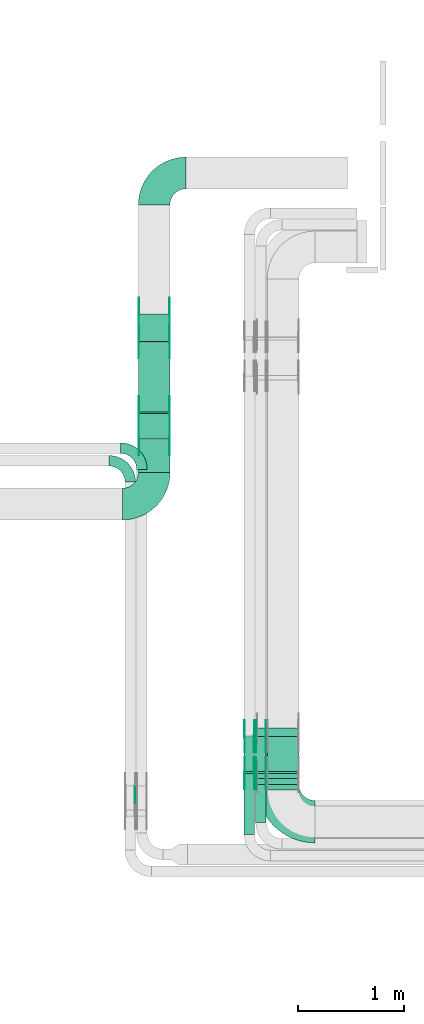
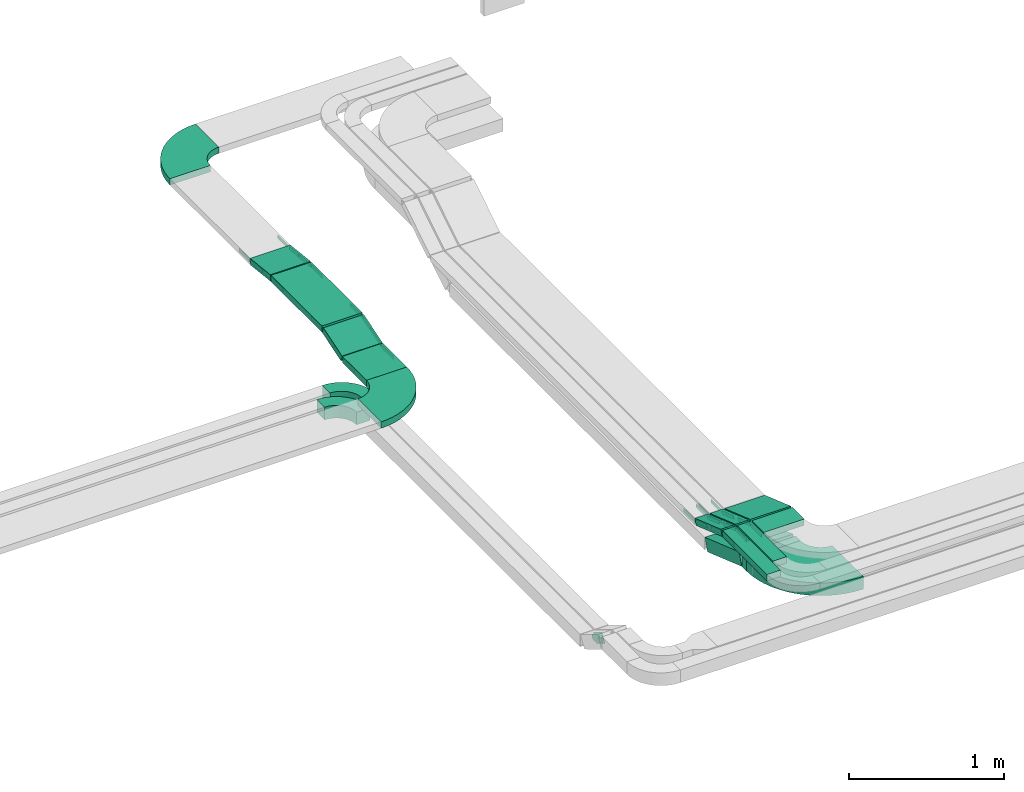
# One storey, part 6 of 27: 38 flow fittings, 12 flow segments.
"""IFC2X3 building model written with IfcOpenShell, lengths in millimetres."""

from ifc_helpers import new_model, entity, si_unit, converted_unit, derived_unit, direction, frame, frame_2d, origin, origin_2d_with_axis, place, context, subcontext, project, spatial, polyline, circle_curve, parameter, trimmed, segment, composite_curve, rectangle, outline, extrude, source, transform, mapped, material, type_object, type_shapes, element, save


model = new_model("IFC2X3")

# Units and contexts
model_context = context("Model", 3, precision=0.01, world=origin(), true_north=direction((6.12303176911189e-17, 1.0)))
body_context = subcontext(model_context, "Body", "Model", "MODEL_VIEW")
ifc_project = project(units=[si_unit("LENGTHUNIT", "METRE", prefix="MILLI"), si_unit("AREAUNIT", "SQUARE_METRE"), si_unit("VOLUMEUNIT", "CUBIC_METRE"), converted_unit("PLANEANGLEUNIT", "DEGREE", entity("IfcRatioMeasure", 0.0174532925199433), si_unit("PLANEANGLEUNIT", "RADIAN"), dimensions=[0, 0, 0, 0, 0, 0, 0]), si_unit("MASSUNIT", "GRAM", prefix="KILO"), derived_unit("MASSDENSITYUNIT", [(si_unit("MASSUNIT", "GRAM", prefix="KILO"), 1), (si_unit("LENGTHUNIT", "METRE"), -3)]), derived_unit("MOMENTOFINERTIAUNIT", [(si_unit("LENGTHUNIT", "METRE"), 4)]), si_unit("TIMEUNIT", "SECOND"), si_unit("FREQUENCYUNIT", "HERTZ"), si_unit("THERMODYNAMICTEMPERATUREUNIT", "DEGREE_CELSIUS"), derived_unit("THERMALTRANSMITTANCEUNIT", [(si_unit("MASSUNIT", "GRAM", prefix="KILO"), 1), (si_unit("THERMODYNAMICTEMPERATUREUNIT", "KELVIN"), -1), (si_unit("TIMEUNIT", "SECOND"), -3)]), derived_unit("VOLUMETRICFLOWRATEUNIT", [(si_unit("LENGTHUNIT", "METRE"), 3), (si_unit("TIMEUNIT", "SECOND"), -1)]), derived_unit("MASSFLOWRATEUNIT", [(si_unit("MASSUNIT", "GRAM", prefix="KILO"), 1), (si_unit("TIMEUNIT", "SECOND"), -1)]), derived_unit("ROTATIONALFREQUENCYUNIT", [(si_unit("TIMEUNIT", "SECOND"), -1)]), si_unit("ELECTRICCURRENTUNIT", "AMPERE"), si_unit("ELECTRICVOLTAGEUNIT", "VOLT"), si_unit("POWERUNIT", "WATT"), si_unit("FORCEUNIT", "NEWTON", prefix="KILO"), si_unit("ILLUMINANCEUNIT", "LUX"), si_unit("LUMINOUSFLUXUNIT", "LUMEN"), si_unit("LUMINOUSINTENSITYUNIT", "CANDELA"), derived_unit("USERDEFINED", [(si_unit("MASSUNIT", "GRAM", prefix="KILO"), -1), (si_unit("LENGTHUNIT", "METRE"), -2), (si_unit("TIMEUNIT", "SECOND"), 3), (si_unit("LUMINOUSFLUXUNIT", "LUMEN"), 1)]), derived_unit("LINEARVELOCITYUNIT", [(si_unit("LENGTHUNIT", "METRE"), 1), (si_unit("TIMEUNIT", "SECOND"), -1)]), si_unit("PRESSUREUNIT", "PASCAL"), derived_unit("USERDEFINED", [(si_unit("LENGTHUNIT", "METRE"), -2), (si_unit("MASSUNIT", "GRAM", prefix="KILO"), 1), (si_unit("TIMEUNIT", "SECOND"), -2)]), derived_unit("LINEARFORCEUNIT", [(si_unit("MASSUNIT", "GRAM", prefix="KILO"), 1), (si_unit("LENGTHUNIT", "METRE"), 1), (si_unit("TIMEUNIT", "SECOND"), -2), (si_unit("LENGTHUNIT", "METRE"), -1)]), derived_unit("PLANARFORCEUNIT", [(si_unit("MASSUNIT", "GRAM", prefix="KILO"), 1), (si_unit("LENGTHUNIT", "METRE"), 1), (si_unit("TIMEUNIT", "SECOND"), -2), (si_unit("LENGTHUNIT", "METRE"), -2)])], contexts=[model_context])

# Site, building, storey
site_placement = place(None, origin())
site = spatial("IfcSite", under=ifc_project, at=site_placement, CompositionType="ELEMENT")
building_placement = place(site_placement, origin())
building = spatial("IfcBuilding", under=site, at=building_placement, CompositionType="ELEMENT")
storey_placement = place(building_placement, origin())
storey = spatial("IfcBuildingStorey", under=building, at=storey_placement, CompositionType="ELEMENT", Elevation=0.0)

# Flow segments
cable_carrier_segment_type = type_object("IfcCableCarrierSegmentType", PredefinedType="CABLETRAYSEGMENT")
flow_segment_1_placement = place(storey_placement, frame((14180.0, 12648.73, 3230.0)))
element("IfcFlowSegment", 1, at=flow_segment_1_placement, inside=storey, type_object=cable_carrier_segment_type, context=body_context, shape_type="SweptSolid", body=[
    extrude(rectangle(XDim=656.864231681176, YDim=300.000000000001, at=origin_2d_with_axis()), frame((150.0, 328.43, 0.0), z_axis=(0.0, 0.0, 1.0), x_axis=(0.0, -1.0, 0.0)), (0.0, 0.0, 1.0), 50.0000000000011),
])
flow_segment_2_placement = place(storey_placement, frame((15400.0, 9071.0, 3350.0)))
element("IfcFlowSegment", 2, at=flow_segment_2_placement, inside=storey, type_object=cable_carrier_segment_type, context=body_context, shape_type="SweptSolid", body=[
    extrude(rectangle(XDim=153.10288471087, YDim=300.000000000001, at=origin_2d_with_axis()), frame((150.0, 76.55, 0.0), z_axis=(0.0, 0.0, 1.0), x_axis=(0.0, 1.0, 0.0)), (0.0, 0.0, 1.0), 49.9999999999995),
])
flow_segment_3_placement = place(storey_placement, frame((15290.0, 8761.0, 3350.0)))
element("IfcFlowSegment", 3, at=flow_segment_3_placement, inside=storey, type_object=cable_carrier_segment_type, context=body_context, shape_type="SweptSolid", body=[
    extrude(rectangle(XDim=463.102884710998, YDim=99.9999999999989, at=origin_2d_with_axis()), frame((50.0, 231.55, 0.0), z_axis=(0.0, 0.0, 1.0), x_axis=(0.0, 1.0, 0.0)), (0.0, 0.0, 1.0), 49.9999999999989),
])
flow_segment_4_placement = place(storey_placement, frame((15180.0, 8651.0, 3350.0)))
element("IfcFlowSegment", 4, at=flow_segment_4_placement, inside=storey, type_object=cable_carrier_segment_type, context=body_context, shape_type="SweptSolid", body=[
    extrude(rectangle(XDim=573.102884710878, YDim=99.9999999999989, at=origin_2d_with_axis()), frame((50.0, 286.55, 0.0), z_axis=(0.0, 0.0, 1.0), x_axis=(0.0, 1.0, 0.0)), (0.0, 0.0, 1.0), 50.0000000000005),
])
flow_segment_5_placement = place(storey_placement, frame((15400.0, 9227.36, 3233.32)))
element("IfcFlowSegment", 5, at=flow_segment_5_placement, inside=storey, type_object=cable_carrier_segment_type, context=body_context, shape_type="SweptSolid", body=[
    extrude(rectangle(XDim=50.0000000000003, YDim=353.648950469399, at=frame_2d((0.0, 0.0), x_axis=(0.0, 1.0))), frame((0.0, 175.23, 81.68), z_axis=(1.0, 0.0, 0.0), x_axis=(0.0, 0.944549723773447, -0.328368420100814)), (0.0, 0.0, 1.0), 299.999999999999),
])
flow_segment_6_placement = place(storey_placement, frame((15290.0, 9227.36, 3233.32)))
element("IfcFlowSegment", 6, at=flow_segment_6_placement, inside=storey, type_object=cable_carrier_segment_type, context=body_context, shape_type="SweptSolid", body=[
    extrude(rectangle(XDim=50.0000000000002, YDim=353.6489504697, at=frame_2d((0.0, 0.0), x_axis=(0.0, 1.0))), frame((0.0, 175.23, 81.68), z_axis=(1.0, 0.0, 0.0), x_axis=(0.0, 0.944549723773509, -0.328368420100635)), (0.0, 0.0, 1.0), 100.000000000001),
])
flow_segment_7_placement = place(storey_placement, frame((15180.0, 9227.36, 3233.32)))
element("IfcFlowSegment", 7, at=flow_segment_7_placement, inside=storey, type_object=cable_carrier_segment_type, context=body_context, shape_type="SweptSolid", body=[
    extrude(rectangle(XDim=50.0000000000002, YDim=353.648950469667, at=frame_2d((0.0, 0.0), x_axis=(0.0, 1.0))), frame((0.0, 175.23, 81.68), z_axis=(1.0, 0.0, 0.0), x_axis=(0.0, 0.944549723773509, -0.328368420100635)), (0.0, 0.0, 1.0), 100.000000000001),
])
flow_segment_8_placement = place(storey_placement, frame((15300.0, 9121.0, 3100.0)))
element("IfcFlowSegment", 8, at=flow_segment_8_placement, inside=storey, type_object=cable_carrier_segment_type, context=body_context, shape_type="SweptSolid", body=[
    extrude(rectangle(XDim=58.881233599423, YDim=400.0, at=origin_2d_with_axis()), frame((200.0, 29.44, 0.0), z_axis=(0.0, 0.0, 1.0), x_axis=(0.0, 1.0, 0.0)), (0.0, 0.0, 1.0), 100.0),
])
flow_segment_9_placement = place(storey_placement, frame((15300.0, 9183.14, 2946.1)))
element("IfcFlowSegment", 9, at=flow_segment_9_placement, inside=storey, type_object=cable_carrier_segment_type, context=body_context, shape_type="SweptSolid", body=[
    extrude(rectangle(XDim=100.0, YDim=467.020041940275, at=frame_2d((0.0, 0.0), x_axis=(0.0, 1.0))), frame((0.0, 236.98, 123.9), z_axis=(1.0, 0.0, 0.0), x_axis=(0.0, 0.944549723773432, -0.328368420100856)), (0.0, 0.0, 1.0), 400.0),
])
flow_segment_10_placement = place(storey_placement, frame((14180.0, 13308.04, 3200.45)))
element("IfcFlowSegment", 10, at=flow_segment_10_placement, inside=storey, type_object=cable_carrier_segment_type, context=body_context, shape_type="SweptSolid", body=[
    extrude(rectangle(XDim=49.9999999999999, YDim=262.697627872475, at=frame_2d((0.0, 0.0), x_axis=(0.0, 1.0))), frame((0.0, 133.32, 39.55), z_axis=(1.0, 0.0, 0.0), x_axis=(0.0, 0.993712801032518, -0.111959229472644)), (0.0, 0.0, 1.0), 300.000000000001),
])
flow_segment_11_placement = place(storey_placement, frame((14180.0, 12076.27, 3150.0)))
element("IfcFlowSegment", 11, at=flow_segment_11_placement, inside=storey, type_object=cable_carrier_segment_type, context=body_context, shape_type="SweptSolid", body=[
    extrude(rectangle(XDim=310.302662480206, YDim=300.000000000001, at=origin_2d_with_axis()), frame((150.0, 155.15, 0.0), z_axis=(0.0, 0.0, 1.0), x_axis=(0.0, 1.0, 0.0)), (0.0, 0.0, 1.0), 50.0),
])
flow_segment_12_placement = place(storey_placement, frame((14180.0, 12389.74, 3152.85)))
element("IfcFlowSegment", 12, at=flow_segment_12_placement, inside=storey, type_object=cable_carrier_segment_type, context=body_context, shape_type="SweptSolid", body=[
    extrude(rectangle(XDim=49.9999999999991, YDim=252.566107987127, at=frame_2d((0.0, 0.0), x_axis=(0.0, 1.0))), frame((0.0, 127.91, 62.15), z_axis=(1.0, 0.0, 0.0), x_axis=(0.0, -0.952827460672093, -0.303512487698893)), (0.0, 0.0, 1.0), 300.000000000003),
])

# Flow fittings
ifc_material_1 = material()
cable_carrier_fitting_type_1 = type_object("IfcCableCarrierFittingType", Name="470_DKC_S5_Variable Angle Elbow 0-45:-", PredefinedType="NOTDEFINED", material=ifc_material_1)
shared_shape_1 = source(origin(), body_context, "Body", "SweptSolid", [
    extrude(outline(composite_curve([segment(polyline([(-150.75, -300.25), (-149.75, -300.25)]), True, "CONTINUOUS"), segment(trimmed(circle_curve(frame_2d((-149.75, 149.75), x_axis=(0.0, -1.0)), 450.0), [parameter(0.0)], [parameter(90.0000000000001)], True, "PARAMETER"), True, "CONTINUOUS"), segment(polyline([(300.25, 149.75), (300.25, 150.75)]), True, "CONTINUOUS"), segment(polyline([(300.25, 150.75), (0.25, 150.75)]), True, "CONTINUOUS"), segment(polyline([(0.25, 150.75), (0.25, 149.75)]), True, "CONTINUOUS"), segment(trimmed(circle_curve(frame_2d((-149.75, 149.75), x_axis=(0.0, -1.0)), 150.0), [parameter(0.0)], [parameter(90.0000000000001)], True, "PARAMETER"), False, "CONTINUOUS"), segment(polyline([(-149.75, -0.25), (-150.75, -0.25)]), True, "CONTINUOUS"), segment(polyline([(-150.75, -0.25), (-150.75, -300.25)]), True, "CONTINUOUS")], self_intersect=False)), frame((-150.25, 150.25, -25.0)), (0.0, 0.0, 1.0), 49.9999999999974),
])
type_shapes(cable_carrier_fitting_type_1, [shared_shape_1])
flow_fitting_1_placement = place(storey_placement, frame((14330.0, 14907.61, 3225.0), z_axis=(0.0, 0.0, 1.0), x_axis=(-1.0, 0.0, 0.0)))
element("IfcFlowFitting", 13, at=flow_fitting_1_placement, inside=storey, type_object=cable_carrier_fitting_type_1, material=ifc_material_1, Name="470_DKC_S5_Variable Angle Elbow 0-45:-", ObjectType="470_DKC_S5_Variable Angle Elbow 0-45:-", context=body_context, shape_type="MappedRepresentation", body=[
    mapped(shared_shape_1, transform((0.0, 0.0, 0.0), scale=1.0)),
])
flow_fitting_2_placement = place(storey_placement, frame((14330.0, 11775.27, 3175.0)))
element("IfcFlowFitting", 14, at=flow_fitting_2_placement, inside=storey, type_object=cable_carrier_fitting_type_1, material=ifc_material_1, Name="470_DKC_S5_Variable Angle Elbow 0-45:-", ObjectType="470_DKC_S5_Variable Angle Elbow 0-45:-", context=body_context, shape_type="MappedRepresentation", body=[
    mapped(shared_shape_1, transform((0.0, 0.0, 0.0), scale=1.0)),
])
ifc_material_2 = material(Name="G")
cable_carrier_fitting_type_2 = type_object("IfcCableCarrierFittingType", PredefinedType="NOTDEFINED", material=ifc_material_2)
shared_shape_2 = source(origin(), body_context, "Body", "SweptSolid", [
    extrude(outline(composite_curve([segment(trimmed(circle_curve(frame_2d((-44.59, 0.0), x_axis=(1.0, 0.0)), 12.5), [parameter(90.0000000000007)], [parameter(270.0)], True, "PARAMETER"), True, "CONTINUOUS"), segment(polyline([(-44.59, -12.5), (-33.09, -12.5)]), True, "CONTINUOUS"), segment(polyline([(-33.09, -12.5), (-31.23, -14.5)]), True, "CONTINUOUS"), segment(polyline([(-31.23, -14.5), (108.91, -14.5)]), True, "CONTINUOUS"), segment(polyline([(108.91, -14.5), (108.91, 14.5)]), True, "CONTINUOUS"), segment(polyline([(108.91, 14.5), (-31.23, 14.5)]), True, "CONTINUOUS"), segment(polyline([(-31.23, 14.5), (-33.09, 12.5)]), True, "CONTINUOUS"), segment(polyline([(-33.09, 12.5), (-44.59, 12.5)]), True, "CONTINUOUS")], self_intersect=False)), frame((44.59, 0.0, 0.0), z_axis=(0.0, 0.0, -1.0), x_axis=(1.0, 0.0, 0.0)), (0.0, 0.0, -1.0), 2.0),
])
type_shapes(cable_carrier_fitting_type_2, [shared_shape_2])
flow_fitting_3_placement = place(storey_placement, frame((15385.46, 9230.0, 3375.0), z_axis=(1.0, 0.0, 0.0), x_axis=(0.0, -1.0, 0.0)))
element("IfcFlowFitting", 15, at=flow_fitting_3_placement, inside=storey, type_object=cable_carrier_fitting_type_2, material=ifc_material_2, context=body_context, shape_type="MappedRepresentation", body=[
    mapped(shared_shape_2, transform((0.0, 0.0, 0.0), scale=1.0)),
])
cable_carrier_fitting_type_3 = type_object("IfcCableCarrierFittingType", PredefinedType="NOTDEFINED", material=ifc_material_2)
type_shapes(cable_carrier_fitting_type_3, [shared_shape_2])
flow_fitting_4_placement = place(storey_placement, frame((15296.54, 9230.0, 3375.0), z_axis=(-1.0, 0.0, 0.0), x_axis=(0.0, 0.94454972377348, -0.328368420100718)))
element("IfcFlowFitting", 16, at=flow_fitting_4_placement, inside=storey, type_object=cable_carrier_fitting_type_3, material=ifc_material_2, context=body_context, shape_type="MappedRepresentation", body=[
    mapped(shared_shape_2, transform((0.0, 0.0, 0.0), scale=1.0)),
])
flow_fitting_5_placement = place(storey_placement, frame((15275.46, 9230.0, 3375.0), z_axis=(1.0, 0.0, 0.0), x_axis=(0.0, -1.0, 0.0)))
element("IfcFlowFitting", 17, at=flow_fitting_5_placement, inside=storey, type_object=cable_carrier_fitting_type_2, material=ifc_material_2, context=body_context, shape_type="MappedRepresentation", body=[
    mapped(shared_shape_2, transform((0.0, 0.0, 0.0), scale=1.0)),
])
flow_fitting_6_placement = place(storey_placement, frame((15186.54, 9230.0, 3375.0), z_axis=(-1.0, 0.0, 0.0), x_axis=(0.0, 0.94454972377348, -0.328368420100718)))
element("IfcFlowFitting", 18, at=flow_fitting_6_placement, inside=storey, type_object=cable_carrier_fitting_type_3, material=ifc_material_2, context=body_context, shape_type="MappedRepresentation", body=[
    mapped(shared_shape_2, transform((0.0, 0.0, 0.0), scale=1.0)),
])
flow_fitting_7_placement = place(storey_placement, frame((15385.46, 9575.18, 3255.0), z_axis=(1.0, 0.0, 0.0), x_axis=(0.0, 1.0, 0.0)))
element("IfcFlowFitting", 19, at=flow_fitting_7_placement, inside=storey, type_object=cable_carrier_fitting_type_2, material=ifc_material_2, context=body_context, shape_type="MappedRepresentation", body=[
    mapped(shared_shape_2, transform((0.0, 0.0, 0.0), scale=1.0)),
])
flow_fitting_8_placement = place(storey_placement, frame((15296.54, 9575.18, 3255.0), z_axis=(-1.0, 0.0, 0.0), x_axis=(0.0, -0.944549723773511, 0.328368420100629)))
element("IfcFlowFitting", 20, at=flow_fitting_8_placement, inside=storey, type_object=cable_carrier_fitting_type_3, material=ifc_material_2, context=body_context, shape_type="MappedRepresentation", body=[
    mapped(shared_shape_2, transform((0.0, 0.0, 0.0), scale=1.0)),
])
flow_fitting_9_placement = place(storey_placement, frame((15275.46, 9575.18, 3255.0), z_axis=(1.0, 0.0, 0.0), x_axis=(0.0, 1.0, 0.0)))
element("IfcFlowFitting", 21, at=flow_fitting_9_placement, inside=storey, type_object=cable_carrier_fitting_type_2, material=ifc_material_2, context=body_context, shape_type="MappedRepresentation", body=[
    mapped(shared_shape_2, transform((0.0, 0.0, 0.0), scale=1.0)),
])
flow_fitting_10_placement = place(storey_placement, frame((15186.54, 9575.18, 3255.0), z_axis=(-1.0, 0.0, 0.0), x_axis=(0.0, -0.944549723773511, 0.328368420100629)))
element("IfcFlowFitting", 22, at=flow_fitting_10_placement, inside=storey, type_object=cable_carrier_fitting_type_3, material=ifc_material_2, context=body_context, shape_type="MappedRepresentation", body=[
    mapped(shared_shape_2, transform((0.0, 0.0, 0.0), scale=1.0)),
])
flow_fitting_11_placement = place(storey_placement, frame((14184.54, 13574.5, 3225.0), z_axis=(-1.0, 0.0, 0.0), x_axis=(0.0, -0.993712801032518, 0.111959229472643)))
element("IfcFlowFitting", 23, at=flow_fitting_11_placement, inside=storey, type_object=cable_carrier_fitting_type_2, material=ifc_material_2, context=body_context, shape_type="MappedRepresentation", body=[
    mapped(shared_shape_2, transform((0.0, 0.0, 0.0), scale=1.0)),
])
flow_fitting_12_placement = place(storey_placement, frame((14473.46, 13574.5, 3225.0), z_axis=(1.0, 0.0, 0.0), x_axis=(0.0, 1.0, 0.0)))
element("IfcFlowFitting", 24, at=flow_fitting_12_placement, inside=storey, type_object=cable_carrier_fitting_type_3, material=ifc_material_2, context=body_context, shape_type="MappedRepresentation", body=[
    mapped(shared_shape_2, transform((0.0, 0.0, 0.0), scale=1.0)),
])
flow_fitting_13_placement = place(storey_placement, frame((14475.46, 13308.23, 3255.0), z_axis=(1.0, 0.0, 0.0), x_axis=(0.0, -1.0, 0.0)))
element("IfcFlowFitting", 25, at=flow_fitting_13_placement, inside=storey, type_object=cable_carrier_fitting_type_2, material=ifc_material_2, context=body_context, shape_type="MappedRepresentation", body=[
    mapped(shared_shape_2, transform((0.0, 0.0, 0.0), scale=1.0)),
])
flow_fitting_14_placement = place(storey_placement, frame((14186.54, 13308.23, 3255.0), z_axis=(-1.0, 0.0, 0.0), x_axis=(0.0, 0.993712801032518, -0.111959229472637)))
element("IfcFlowFitting", 26, at=flow_fitting_14_placement, inside=storey, type_object=cable_carrier_fitting_type_3, material=ifc_material_2, context=body_context, shape_type="MappedRepresentation", body=[
    mapped(shared_shape_2, transform((0.0, 0.0, 0.0), scale=1.0)),
])
flow_fitting_15_placement = place(storey_placement, frame((14475.46, 12643.23, 3255.0), z_axis=(1.0, 0.0, 0.0), x_axis=(0.0, -0.952827460672923, -0.303512487696289)))
element("IfcFlowFitting", 27, at=flow_fitting_15_placement, inside=storey, type_object=cable_carrier_fitting_type_2, material=ifc_material_2, context=body_context, shape_type="MappedRepresentation", body=[
    mapped(shared_shape_2, transform((0.0, 0.0, 0.0), scale=1.0)),
])
flow_fitting_16_placement = place(storey_placement, frame((14186.54, 12643.23, 3255.0), z_axis=(-1.0, 0.0, 0.0), x_axis=(0.0, 1.0, 0.0)))
element("IfcFlowFitting", 28, at=flow_fitting_16_placement, inside=storey, type_object=cable_carrier_fitting_type_3, material=ifc_material_2, context=body_context, shape_type="MappedRepresentation", body=[
    mapped(shared_shape_2, transform((0.0, 0.0, 0.0), scale=1.0)),
])
flow_fitting_17_placement = place(storey_placement, frame((14475.46, 12392.08, 3175.0), z_axis=(1.0, 0.0, 0.0), x_axis=(0.0, 0.952827460672923, 0.303512487696289)))
element("IfcFlowFitting", 29, at=flow_fitting_17_placement, inside=storey, type_object=cable_carrier_fitting_type_2, material=ifc_material_2, context=body_context, shape_type="MappedRepresentation", body=[
    mapped(shared_shape_2, transform((0.0, 0.0, 0.0), scale=1.0)),
])
flow_fitting_18_placement = place(storey_placement, frame((14186.54, 12392.08, 3175.0), z_axis=(-1.0, 0.0, 0.0), x_axis=(0.0, -1.0, 0.0)))
element("IfcFlowFitting", 30, at=flow_fitting_18_placement, inside=storey, type_object=cable_carrier_fitting_type_3, material=ifc_material_2, context=body_context, shape_type="MappedRepresentation", body=[
    mapped(shared_shape_2, transform((0.0, 0.0, 0.0), scale=1.0)),
])
cable_carrier_fitting_type_4 = type_object("IfcCableCarrierFittingType", PredefinedType="NOTDEFINED", material=ifc_material_2)
shared_shape_3 = source(origin(), body_context, "Body", "SweptSolid", [
    extrude(outline(composite_curve([segment(trimmed(circle_curve(frame_2d((-44.59, 0.0), x_axis=(1.0, 0.0)), 12.5), [parameter(90.0000000000007)], [parameter(270.0)], True, "PARAMETER"), True, "CONTINUOUS"), segment(polyline([(-44.59, -12.5), (-33.09, -12.5)]), True, "CONTINUOUS"), segment(polyline([(-33.09, -12.5), (-31.23, -14.5)]), True, "CONTINUOUS"), segment(polyline([(-31.23, -14.5), (108.91, -14.5)]), True, "CONTINUOUS"), segment(polyline([(108.91, -14.5), (108.91, 14.5)]), True, "CONTINUOUS"), segment(polyline([(108.91, 14.5), (-31.23, 14.5)]), True, "CONTINUOUS"), segment(polyline([(-31.23, 14.5), (-33.09, 12.5)]), True, "CONTINUOUS"), segment(polyline([(-33.09, 12.5), (-44.59, 12.5)]), True, "CONTINUOUS")], self_intersect=False)), frame((44.59, 0.0, 0.0)), (0.0, 0.0, 1.0), 2.0),
])
type_shapes(cable_carrier_fitting_type_4, [shared_shape_3])
flow_fitting_19_placement = place(storey_placement, frame((15294.54, 9230.0, 3375.0), z_axis=(-1.0, 0.0, 0.0), x_axis=(0.0, -1.0, 0.0)))
element("IfcFlowFitting", 31, at=flow_fitting_19_placement, inside=storey, type_object=cable_carrier_fitting_type_4, material=ifc_material_2, context=body_context, shape_type="MappedRepresentation", body=[
    mapped(shared_shape_3, transform((0.0, 0.0, 0.0), scale=1.0)),
])
cable_carrier_fitting_type_5 = type_object("IfcCableCarrierFittingType", PredefinedType="NOTDEFINED", material=ifc_material_2)
type_shapes(cable_carrier_fitting_type_5, [shared_shape_3])
flow_fitting_20_placement = place(storey_placement, frame((15383.46, 9230.0, 3375.0), z_axis=(1.0, 0.0, 0.0), x_axis=(0.0, 0.94454972377348, -0.328368420100718)))
element("IfcFlowFitting", 32, at=flow_fitting_20_placement, inside=storey, type_object=cable_carrier_fitting_type_5, material=ifc_material_2, context=body_context, shape_type="MappedRepresentation", body=[
    mapped(shared_shape_3, transform((0.0, 0.0, 0.0), scale=1.0)),
])
flow_fitting_21_placement = place(storey_placement, frame((15184.54, 9230.0, 3375.0), z_axis=(-1.0, 0.0, 0.0), x_axis=(0.0, -1.0, 0.0)))
element("IfcFlowFitting", 33, at=flow_fitting_21_placement, inside=storey, type_object=cable_carrier_fitting_type_4, material=ifc_material_2, context=body_context, shape_type="MappedRepresentation", body=[
    mapped(shared_shape_3, transform((0.0, 0.0, 0.0), scale=1.0)),
])
flow_fitting_22_placement = place(storey_placement, frame((15273.46, 9230.0, 3375.0), z_axis=(1.0, 0.0, 0.0), x_axis=(0.0, 0.94454972377348, -0.328368420100718)))
element("IfcFlowFitting", 34, at=flow_fitting_22_placement, inside=storey, type_object=cable_carrier_fitting_type_5, material=ifc_material_2, context=body_context, shape_type="MappedRepresentation", body=[
    mapped(shared_shape_3, transform((0.0, 0.0, 0.0), scale=1.0)),
])
flow_fitting_23_placement = place(storey_placement, frame((15294.54, 9575.18, 3255.0), z_axis=(-1.0, 0.0, 0.0), x_axis=(0.0, 1.0, 0.0)))
element("IfcFlowFitting", 35, at=flow_fitting_23_placement, inside=storey, type_object=cable_carrier_fitting_type_4, material=ifc_material_2, context=body_context, shape_type="MappedRepresentation", body=[
    mapped(shared_shape_3, transform((0.0, 0.0, 0.0), scale=1.0)),
])
flow_fitting_24_placement = place(storey_placement, frame((15383.46, 9575.18, 3255.0), z_axis=(1.0, 0.0, 0.0), x_axis=(0.0, -0.944549723773511, 0.328368420100629)))
element("IfcFlowFitting", 36, at=flow_fitting_24_placement, inside=storey, type_object=cable_carrier_fitting_type_5, material=ifc_material_2, context=body_context, shape_type="MappedRepresentation", body=[
    mapped(shared_shape_3, transform((0.0, 0.0, 0.0), scale=1.0)),
])
flow_fitting_25_placement = place(storey_placement, frame((15184.54, 9575.18, 3255.0), z_axis=(-1.0, 0.0, 0.0), x_axis=(0.0, 1.0, 0.0)))
element("IfcFlowFitting", 37, at=flow_fitting_25_placement, inside=storey, type_object=cable_carrier_fitting_type_4, material=ifc_material_2, context=body_context, shape_type="MappedRepresentation", body=[
    mapped(shared_shape_3, transform((0.0, 0.0, 0.0), scale=1.0)),
])
flow_fitting_26_placement = place(storey_placement, frame((15273.46, 9575.18, 3255.0), z_axis=(1.0, 0.0, 0.0), x_axis=(0.0, -0.944549723773511, 0.328368420100629)))
element("IfcFlowFitting", 38, at=flow_fitting_26_placement, inside=storey, type_object=cable_carrier_fitting_type_5, material=ifc_material_2, context=body_context, shape_type="MappedRepresentation", body=[
    mapped(shared_shape_3, transform((0.0, 0.0, 0.0), scale=1.0)),
])
flow_fitting_27_placement = place(storey_placement, frame((14475.46, 13574.5, 3225.0), z_axis=(1.0, 0.0, 0.0), x_axis=(0.0, -0.993712801032518, 0.111959229472643)))
element("IfcFlowFitting", 39, at=flow_fitting_27_placement, inside=storey, type_object=cable_carrier_fitting_type_4, material=ifc_material_2, context=body_context, shape_type="MappedRepresentation", body=[
    mapped(shared_shape_3, transform((0.0, 0.0, 0.0), scale=1.0)),
])
flow_fitting_28_placement = place(storey_placement, frame((14186.54, 13574.5, 3225.0), z_axis=(-1.0, 0.0, 0.0), x_axis=(0.0, 1.0, 0.0)))
element("IfcFlowFitting", 40, at=flow_fitting_28_placement, inside=storey, type_object=cable_carrier_fitting_type_5, material=ifc_material_2, context=body_context, shape_type="MappedRepresentation", body=[
    mapped(shared_shape_3, transform((0.0, 0.0, 0.0), scale=1.0)),
])
flow_fitting_29_placement = place(storey_placement, frame((14184.54, 13308.23, 3255.0), z_axis=(-1.0, 0.0, 0.0), x_axis=(0.0, -1.0, 0.0)))
element("IfcFlowFitting", 41, at=flow_fitting_29_placement, inside=storey, type_object=cable_carrier_fitting_type_4, material=ifc_material_2, context=body_context, shape_type="MappedRepresentation", body=[
    mapped(shared_shape_3, transform((0.0, 0.0, 0.0), scale=1.0)),
])
flow_fitting_30_placement = place(storey_placement, frame((14473.46, 13308.23, 3255.0), z_axis=(1.0, 0.0, 0.0), x_axis=(0.0, 0.993712801032518, -0.111959229472637)))
element("IfcFlowFitting", 42, at=flow_fitting_30_placement, inside=storey, type_object=cable_carrier_fitting_type_5, material=ifc_material_2, context=body_context, shape_type="MappedRepresentation", body=[
    mapped(shared_shape_3, transform((0.0, 0.0, 0.0), scale=1.0)),
])
flow_fitting_31_placement = place(storey_placement, frame((14184.54, 12643.23, 3255.0), z_axis=(-1.0, 0.0, 0.0), x_axis=(0.0, -0.952827460672923, -0.303512487696289)))
element("IfcFlowFitting", 43, at=flow_fitting_31_placement, inside=storey, type_object=cable_carrier_fitting_type_4, material=ifc_material_2, context=body_context, shape_type="MappedRepresentation", body=[
    mapped(shared_shape_3, transform((0.0, 0.0, 0.0), scale=1.0)),
])
flow_fitting_32_placement = place(storey_placement, frame((14473.46, 12643.23, 3255.0), z_axis=(1.0, 0.0, 0.0), x_axis=(0.0, 1.0, 0.0)))
element("IfcFlowFitting", 44, at=flow_fitting_32_placement, inside=storey, type_object=cable_carrier_fitting_type_5, material=ifc_material_2, context=body_context, shape_type="MappedRepresentation", body=[
    mapped(shared_shape_3, transform((0.0, 0.0, 0.0), scale=1.0)),
])
flow_fitting_33_placement = place(storey_placement, frame((14184.54, 12392.08, 3175.0), z_axis=(-1.0, 0.0, 0.0), x_axis=(0.0, 0.952827460672923, 0.303512487696289)))
element("IfcFlowFitting", 45, at=flow_fitting_33_placement, inside=storey, type_object=cable_carrier_fitting_type_4, material=ifc_material_2, context=body_context, shape_type="MappedRepresentation", body=[
    mapped(shared_shape_3, transform((0.0, 0.0, 0.0), scale=1.0)),
])
flow_fitting_34_placement = place(storey_placement, frame((14473.46, 12392.08, 3175.0), z_axis=(1.0, 0.0, 0.0), x_axis=(0.0, -1.0, 0.0)))
element("IfcFlowFitting", 46, at=flow_fitting_34_placement, inside=storey, type_object=cable_carrier_fitting_type_5, material=ifc_material_2, context=body_context, shape_type="MappedRepresentation", body=[
    mapped(shared_shape_3, transform((0.0, 0.0, 0.0), scale=1.0)),
])
cable_carrier_fitting_type_6 = type_object("IfcCableCarrierFittingType", Name="470_DKC_S5_Variable Angle Elbow 0-45:-", PredefinedType="NOTDEFINED", material=ifc_material_1)
shared_shape_4 = source(origin(), body_context, "Body", "SweptSolid", [
    extrude(outline(composite_curve([segment(polyline([(-100.75, -150.25), (-99.75, -150.25)]), True, "CONTINUOUS"), segment(trimmed(circle_curve(frame_2d((-99.75, 99.75), x_axis=(0.0, -1.0)), 250.0), [parameter(0.0)], [parameter(90.0000000000001)], True, "PARAMETER"), True, "CONTINUOUS"), segment(polyline([(150.25, 99.75), (150.25, 100.75)]), True, "CONTINUOUS"), segment(polyline([(150.25, 100.75), (50.25, 100.75)]), True, "CONTINUOUS"), segment(polyline([(50.25, 100.75), (50.25, 99.75)]), True, "CONTINUOUS"), segment(trimmed(circle_curve(frame_2d((-99.75, 99.75), x_axis=(0.0, -1.0)), 150.0), [parameter(0.0)], [parameter(90.0000000000001)], True, "PARAMETER"), False, "CONTINUOUS"), segment(polyline([(-99.75, -50.25), (-100.75, -50.25)]), True, "CONTINUOUS"), segment(polyline([(-100.75, -50.25), (-100.75, -150.25)]), True, "CONTINUOUS")], self_intersect=False)), frame((-100.25, 100.25, -50.0)), (0.0, 0.0, 1.0), 100.0),
])
type_shapes(cable_carrier_fitting_type_6, [shared_shape_4])
for number, where, z_axis, x_axis, name in (
    (47, (14213.72, 12305.0, 3000.0), (0.0, 0.0, 1.0), (0.0, 1.0, 0.0), "470_DKC_S5_Variable Angle Elbow 0-45:-"),
    (48, (14103.72, 12185.0, 3000.0), (0.0, 0.0, 1.0), (0.0, 1.0, 0.0), "470_DKC_S5_Variable Angle Elbow 0-45:-"),
):
    element("IfcFlowFitting", number, at=place(storey_placement, frame(where, z_axis=z_axis, x_axis=x_axis)), inside=storey, type_object=cable_carrier_fitting_type_6, material=ifc_material_1, Name=name, ObjectType="470_DKC_S5_Variable Angle Elbow 0-45:-", context=body_context, shape_type="MappedRepresentation", body=[
        mapped(shared_shape_4, transform((0.0, 0.0, 0.0), scale=1.0)),
    ])
cable_carrier_fitting_type_7 = type_object("IfcCableCarrierFittingType", PredefinedType="NOTDEFINED", material=ifc_material_2)
shared_shape_5 = source(origin(), body_context, "Body", "SweptSolid", [
    extrude(outline(composite_curve([segment(trimmed(circle_curve(frame_2d((-41.47, 0.0), x_axis=(1.0, 0.0)), 25.0), [parameter(90.0000000000007)], [parameter(270.0)], True, "PARAMETER"), True, "CONTINUOUS"), segment(polyline([(-41.47, -25.0), (-29.97, -25.0)]), True, "CONTINUOUS"), segment(polyline([(-29.97, -25.0), (-28.1, -38.5)]), True, "CONTINUOUS"), segment(polyline([(-28.1, -38.5), (99.53, -38.5)]), True, "CONTINUOUS"), segment(polyline([(99.53, -38.5), (99.53, 38.5)]), True, "CONTINUOUS"), segment(polyline([(99.53, 38.5), (-28.1, 38.5)]), True, "CONTINUOUS"), segment(polyline([(-28.1, 38.5), (-29.97, 25.0)]), True, "CONTINUOUS"), segment(polyline([(-29.97, 25.0), (-41.47, 25.0)]), True, "CONTINUOUS")], self_intersect=False)), frame((41.47, 0.0, 0.0)), (0.0, 0.0, 1.0), 2.0),
])
type_shapes(cable_carrier_fitting_type_7, [shared_shape_5])
flow_fitting_35_placement = place(storey_placement, frame((14147.18, 9089.64, 3000.0), z_axis=(1.0, 0.0, 0.0), x_axis=(0.0, -0.85716730070229, 0.515038074909759)))
element("IfcFlowFitting", 49, at=flow_fitting_35_placement, inside=storey, type_object=cable_carrier_fitting_type_7, material=ifc_material_2, context=body_context, shape_type="MappedRepresentation", body=[
    mapped(shared_shape_5, transform((0.0, 0.0, 0.0), scale=1.0)),
])
cable_carrier_fitting_type_8 = type_object("IfcCableCarrierFittingType", Name="470_DKC_S5_Variable Angle Elbow 0-45:-", PredefinedType="NOTDEFINED", material=ifc_material_1)
shared_shape_6 = source(origin(), body_context, "Body", "SweptSolid", [
    extrude(outline(composite_curve([segment(polyline([(-175.75, -375.25), (-174.75, -375.25)]), True, "CONTINUOUS"), segment(trimmed(circle_curve(frame_2d((-174.75, 174.75), x_axis=(0.0, -1.0)), 550.0), [parameter(0.0)], [parameter(90.0)], True, "PARAMETER"), True, "CONTINUOUS"), segment(polyline([(375.25, 174.75), (375.25, 175.75)]), True, "CONTINUOUS"), segment(polyline([(375.25, 175.75), (-24.75, 175.75)]), True, "CONTINUOUS"), segment(polyline([(-24.75, 175.75), (-24.75, 174.75)]), True, "CONTINUOUS"), segment(trimmed(circle_curve(frame_2d((-174.75, 174.75), x_axis=(0.0, -1.0)), 150.0), [parameter(0.0)], [parameter(90.0)], True, "PARAMETER"), False, "CONTINUOUS"), segment(polyline([(-174.75, 24.75), (-175.75, 24.75)]), True, "CONTINUOUS"), segment(polyline([(-175.75, 24.75), (-175.75, -375.25)]), True, "CONTINUOUS")], self_intersect=False)), frame((-175.25, 175.25, -50.0)), (0.0, 0.0, 1.0), 99.9999999999956),
])
type_shapes(cable_carrier_fitting_type_8, [shared_shape_6])
flow_fitting_36_placement = place(storey_placement, frame((15500.0, 8770.0, 3150.0), z_axis=(0.0, 0.0, 1.0), x_axis=(0.0, -1.0, 0.0)))
element("IfcFlowFitting", 50, at=flow_fitting_36_placement, inside=storey, type_object=cable_carrier_fitting_type_8, material=ifc_material_1, Name="470_DKC_S5_Variable Angle Elbow 0-45:-", ObjectType="470_DKC_S5_Variable Angle Elbow 0-45:-", context=body_context, shape_type="MappedRepresentation", body=[
    mapped(shared_shape_6, transform((0.0, 0.0, 0.0), scale=1.0)),
])

save(model, "model.ifc")
